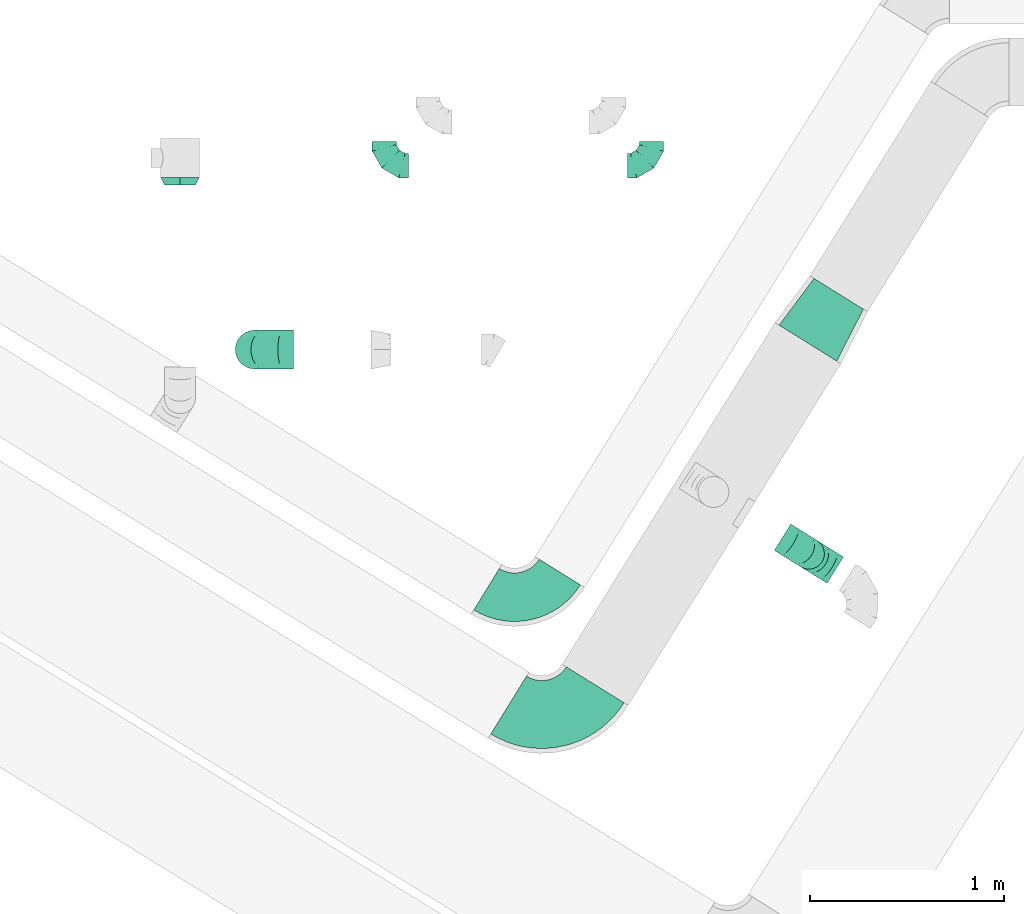
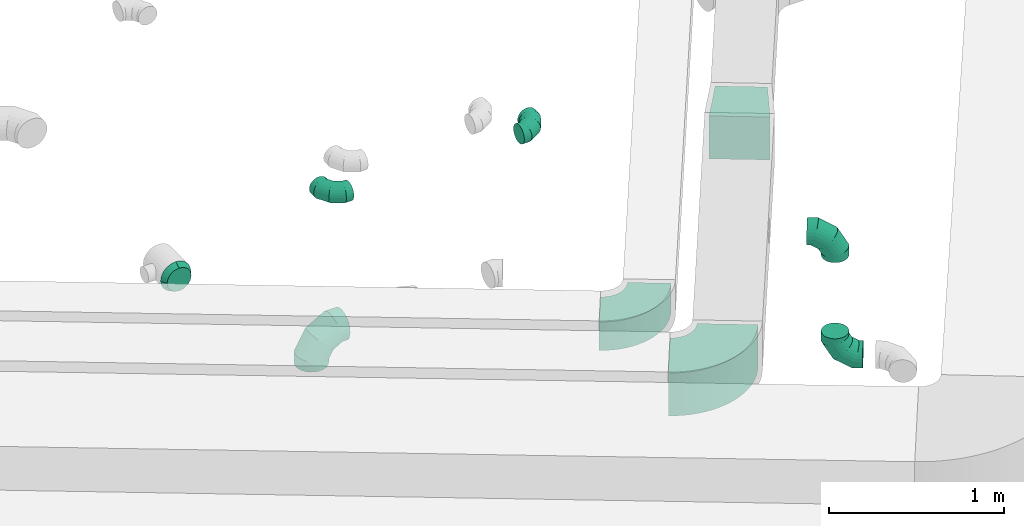
# One storey, part 37 of 97: 9 flow fittings.
"""IFC2X3 building model written with IfcOpenShell, lengths in millimetres."""

from ifc_helpers import new_model, entity, si_unit, converted_unit, derived_unit, direction, frame, frame_2d, origin, place, context, subcontext, project, spatial, polyline, circle_curve, parameter, trimmed, segment, composite_curve, outline, extrude, faceted_brep, source, transform, mapped, material, type_object, type_shapes, element, save


model = new_model("IFC2X3")

# Units and contexts
model_context = context("Model", 3, precision=0.01, world=origin(), true_north=direction((6.12303176911189e-17, 1.0)))
body_context = subcontext(model_context, "Body", "Model", "MODEL_VIEW")
ifc_project = project(units=[si_unit("LENGTHUNIT", "METRE", prefix="MILLI"), si_unit("AREAUNIT", "SQUARE_METRE"), si_unit("VOLUMEUNIT", "CUBIC_METRE"), converted_unit("PLANEANGLEUNIT", "DEGREE", entity("IfcRatioMeasure", 0.0174532925199433), si_unit("PLANEANGLEUNIT", "RADIAN"), dimensions=[0, 0, 0, 0, 0, 0, 0]), si_unit("MASSUNIT", "GRAM", prefix="KILO"), derived_unit("MASSDENSITYUNIT", [(si_unit("MASSUNIT", "GRAM", prefix="KILO"), 1), (si_unit("LENGTHUNIT", "METRE"), -3)]), derived_unit("MOMENTOFINERTIAUNIT", [(si_unit("LENGTHUNIT", "METRE"), 4)]), si_unit("TIMEUNIT", "SECOND"), si_unit("FREQUENCYUNIT", "HERTZ"), si_unit("THERMODYNAMICTEMPERATUREUNIT", "DEGREE_CELSIUS"), derived_unit("THERMALTRANSMITTANCEUNIT", [(si_unit("MASSUNIT", "GRAM", prefix="KILO"), 1), (si_unit("THERMODYNAMICTEMPERATUREUNIT", "KELVIN"), -1), (si_unit("TIMEUNIT", "SECOND"), -3)]), derived_unit("VOLUMETRICFLOWRATEUNIT", [(si_unit("LENGTHUNIT", "METRE"), 3), (si_unit("TIMEUNIT", "SECOND"), -1)]), derived_unit("MASSFLOWRATEUNIT", [(si_unit("MASSUNIT", "GRAM", prefix="KILO"), 1), (si_unit("TIMEUNIT", "SECOND"), -1)]), derived_unit("ROTATIONALFREQUENCYUNIT", [(si_unit("TIMEUNIT", "SECOND"), -1)]), si_unit("ELECTRICCURRENTUNIT", "AMPERE"), si_unit("ELECTRICVOLTAGEUNIT", "VOLT"), si_unit("POWERUNIT", "WATT"), si_unit("FORCEUNIT", "NEWTON", prefix="KILO"), si_unit("ILLUMINANCEUNIT", "LUX"), si_unit("LUMINOUSFLUXUNIT", "LUMEN"), si_unit("LUMINOUSINTENSITYUNIT", "CANDELA"), derived_unit("USERDEFINED", [(si_unit("MASSUNIT", "GRAM", prefix="KILO"), -1), (si_unit("LENGTHUNIT", "METRE"), -2), (si_unit("TIMEUNIT", "SECOND"), 3), (si_unit("LUMINOUSFLUXUNIT", "LUMEN"), 1)]), derived_unit("LINEARVELOCITYUNIT", [(si_unit("LENGTHUNIT", "METRE"), 1), (si_unit("TIMEUNIT", "SECOND"), -1)]), si_unit("PRESSUREUNIT", "PASCAL"), derived_unit("USERDEFINED", [(si_unit("LENGTHUNIT", "METRE"), -2), (si_unit("MASSUNIT", "GRAM", prefix="KILO"), 1), (si_unit("TIMEUNIT", "SECOND"), -2)]), derived_unit("LINEARFORCEUNIT", [(si_unit("MASSUNIT", "GRAM", prefix="KILO"), 1), (si_unit("LENGTHUNIT", "METRE"), 1), (si_unit("TIMEUNIT", "SECOND"), -2), (si_unit("LENGTHUNIT", "METRE"), -1)]), derived_unit("PLANARFORCEUNIT", [(si_unit("MASSUNIT", "GRAM", prefix="KILO"), 1), (si_unit("LENGTHUNIT", "METRE"), 1), (si_unit("TIMEUNIT", "SECOND"), -2), (si_unit("LENGTHUNIT", "METRE"), -2)])], contexts=[model_context])

# Site, building, storey
site_placement = place(None, origin())
site = spatial("IfcSite", under=ifc_project, at=site_placement, CompositionType="ELEMENT")
building_placement = place(site_placement, origin())
building = spatial("IfcBuilding", under=site, at=building_placement, CompositionType="ELEMENT")
storey_placement = place(building_placement, frame((0.0, 0.0, -4900.0)))
storey = spatial("IfcBuildingStorey", under=building, at=storey_placement, CompositionType="ELEMENT", Elevation=-4900.0)

# Flow fittings
ifc_material = material()
duct_fitting_type_1 = type_object("IfcDuctFittingType", PredefinedType="NOTDEFINED", material=ifc_material)
shared_shape_1 = source(origin(), body_context, "Body", "SweptSolid", [
    extrude(outline(polyline([(-164.01, -161.94), (137.03, -161.94), (161.94, 137.03), (-134.95, 186.85), (-164.01, -161.94)])), frame((150.0, 0.0, -150.0), z_axis=(0.0, 0.0, 1.0), x_axis=(0.99654575824488, 0.0830454798537382, 0.0)), (0.0, 0.0, 1.0), 300.0),
])
type_shapes(duct_fitting_type_1, [shared_shape_1])
flow_fitting_1_placement = place(storey_placement, frame((12389.17, 11235.74, 4300.0), z_axis=(0.0, 0.0, 1.0), x_axis=(0.52854381603038, 0.848906022205075, 0.0)))
element("IfcFlowFitting", 1, at=flow_fitting_1_placement, inside=storey, type_object=duct_fitting_type_1, material=ifc_material, context=body_context, shape_type="MappedRepresentation", body=[
    mapped(shared_shape_1, transform((0.0, 0.0, 0.0), scale=1.0)),
])
duct_fitting_type_2 = type_object("IfcDuctFittingType", PredefinedType="NOTDEFINED", material=ifc_material)
shared_shape_2 = source(origin(), body_context, "Body", "Brep", [
    faceted_brep([(-160.0, 0.0, -80.0), (-160.0, -20.71, -77.27), (-160.0, -40.0, -69.28), (-160.0, -56.57, -56.57), (-160.0, -69.28, -40.0), (-160.0, -77.27, -20.71), (-160.0, -80.0, 0.0), (-160.0, -77.27, 20.71), (-160.0, -69.28, 40.0), (-160.0, -56.57, 56.57), (-160.0, -40.0, 69.28), (-160.0, -20.71, 77.27), (-160.0, 0.0, 80.0), (-160.0, 20.71, 77.27), (-160.0, 40.0, 69.28), (-160.0, 56.57, 56.57), (-160.0, 69.28, 40.0), (-160.0, 77.27, 20.71), (-160.0, 80.0, 0.0), (-160.0, 77.27, -20.71), (-160.0, 69.28, -40.0), (-160.0, 56.57, -56.57), (-160.0, 40.0, -69.28), (-160.0, 20.71, -77.27), (-122.68, 20.71, 77.27), (-127.85, 40.0, 69.28), (-117.13, 0.0, 80.0), (-132.29, 56.57, 56.57), (-137.83, 77.27, 20.71), (-138.56, 80.0, 0.0), (-135.69, 69.28, 40.0), (-135.69, 69.28, -40.0), (-132.29, 56.57, -56.57), (-137.83, 77.27, -20.71), (-122.68, 20.71, -77.27), (-117.13, 0.0, -80.0), (-127.85, 40.0, -69.28), (-111.58, -20.71, -77.27), (-106.41, -40.0, -69.28), (-101.97, -56.57, -56.57), (-98.56, -69.28, -40.0), (-96.42, -77.27, -20.71), (-95.69, -80.0, 0.0), (-96.42, -77.27, 20.71), (-98.56, -69.28, 40.0), (-101.97, -56.57, 56.57), (-106.41, -40.0, 69.28), (-111.58, -20.71, 77.27), (-58.03, 58.03, 77.27), (-72.15, 72.15, 69.28), (-42.87, 42.87, 80.0), (-84.28, 84.28, 56.57), (-93.59, 93.59, 40.0), (-99.44, 99.44, 20.71), (-101.44, 101.44, 0.0), (-99.44, 99.44, -20.71), (-93.59, 93.59, -40.0), (-84.28, 84.28, -56.57), (-58.03, 58.03, -77.27), (-42.87, 42.87, -80.0), (-72.15, 72.15, -69.28), (-27.71, 27.71, -77.27), (-13.59, 13.59, -69.28), (-1.46, 1.46, -56.57), (7.85, -7.85, -40.0), (13.7, -13.7, -20.71), (15.69, -15.69, 0.0), (13.7, -13.7, 20.71), (7.85, -7.85, 40.0), (-1.46, 1.46, 56.57), (-13.59, 13.59, 69.28), (-27.71, 27.71, 77.27), (-20.71, 122.68, 77.27), (-40.0, 127.85, 69.28), (0.0, 117.13, 80.0), (-56.57, 132.29, 56.57), (-69.28, 135.69, 40.0), (-77.27, 137.83, 20.71), (-80.0, 138.56, 0.0), (-77.27, 137.83, -20.71), (-69.28, 135.69, -40.0), (-56.57, 132.29, -56.57), (-20.71, 122.68, -77.27), (0.0, 117.13, -80.0), (-40.0, 127.85, -69.28), (20.71, 111.58, -77.27), (40.0, 106.41, -69.28), (56.57, 101.97, -56.57), (69.28, 98.56, -40.0), (77.27, 96.42, -20.71), (80.0, 95.69, 0.0), (77.27, 96.42, 20.71), (69.28, 98.56, 40.0), (56.57, 101.97, 56.57), (40.0, 106.41, 69.28), (20.71, 111.58, 77.27), (-20.71, 160.0, -77.27), (-40.0, 160.0, -69.28), (-56.57, 160.0, -56.57), (-69.28, 160.0, -40.0), (-77.27, 160.0, -20.71), (-80.0, 160.0, 0.0), (-77.27, 160.0, 20.71), (-69.28, 160.0, 40.0), (-56.57, 160.0, 56.57), (-40.0, 160.0, 69.28), (-20.71, 160.0, 77.27), (0.0, 160.0, 80.0), (20.71, 160.0, 77.27), (40.0, 160.0, 69.28), (56.57, 160.0, 56.57), (69.28, 160.0, 40.0), (77.27, 160.0, 20.71), (80.0, 160.0, 0.0), (77.27, 160.0, -20.71), (69.28, 160.0, -40.0), (56.57, 160.0, -56.57), (40.0, 160.0, -69.28), (20.71, 160.0, -77.27), (0.0, 160.0, -80.0)], [[[0, 1, 2, 3, 4, 5, 6, 7, 8, 9, 10, 11, 12, 13, 14, 15, 16, 17, 18, 19, 20, 21, 22, 23]], [[24, 25, 14, 13]], [[26, 24, 13, 12]], [[14, 25, 27, 15]], [[28, 29, 18, 17]], [[30, 28, 17, 16]], [[15, 27, 30, 16]], [[20, 31, 32, 21]], [[33, 31, 20, 19]], [[18, 29, 33, 19]], [[34, 35, 0, 23]], [[36, 34, 23, 22]], [[32, 36, 22, 21]], [[1, 0, 35, 37]], [[2, 1, 37, 38]], [[3, 2, 38, 39]], [[5, 4, 40, 41]], [[6, 5, 41, 42]], [[39, 40, 4, 3]], [[6, 42, 43, 7]], [[7, 43, 44, 8]], [[8, 44, 45, 9]], [[9, 45, 46, 10]], [[10, 46, 47, 11]], [[26, 12, 11, 47]], [[48, 49, 25, 24]], [[50, 48, 24, 26]], [[27, 25, 49, 51]], [[52, 53, 28, 30]], [[51, 52, 30, 27]], [[29, 28, 53, 54]], [[55, 56, 31, 33]], [[54, 55, 33, 29]], [[32, 31, 56, 57]], [[58, 59, 35, 34]], [[60, 58, 34, 36]], [[57, 60, 36, 32]], [[37, 35, 59, 61]], [[38, 37, 61, 62]], [[39, 38, 62, 63]], [[41, 40, 64, 65]], [[42, 41, 65, 66]], [[63, 64, 40, 39]], [[43, 42, 66, 67]], [[44, 43, 67, 68]], [[68, 69, 45, 44]], [[46, 45, 69, 70]], [[47, 46, 70, 71]], [[26, 47, 71, 50]], [[72, 73, 49, 48]], [[74, 72, 48, 50]], [[51, 49, 73, 75]], [[76, 77, 53, 52]], [[75, 76, 52, 51]], [[54, 53, 77, 78]], [[79, 80, 56, 55]], [[78, 79, 55, 54]], [[57, 56, 80, 81]], [[82, 83, 59, 58]], [[84, 82, 58, 60]], [[81, 84, 60, 57]], [[61, 59, 83, 85]], [[62, 61, 85, 86]], [[63, 62, 86, 87]], [[65, 64, 88, 89]], [[66, 65, 89, 90]], [[87, 88, 64, 63]], [[67, 66, 90, 91]], [[68, 67, 91, 92]], [[92, 93, 69, 68]], [[70, 69, 93, 94]], [[71, 70, 94, 95]], [[50, 71, 95, 74]], [[96, 97, 98, 99, 100, 101, 102, 103, 104, 105, 106, 107, 108, 109, 110, 111, 112, 113, 114, 115, 116, 117, 118, 119]], [[72, 74, 107, 106]], [[73, 72, 106, 105]], [[75, 73, 105, 104]], [[77, 76, 103, 102]], [[78, 77, 102, 101]], [[75, 104, 103, 76]], [[78, 101, 100, 79]], [[79, 100, 99, 80]], [[80, 99, 98, 81]], [[84, 97, 96, 82]], [[82, 96, 119, 83]], [[84, 81, 98, 97]], [[118, 117, 86, 85]], [[119, 118, 85, 83]], [[116, 87, 86, 117]], [[88, 115, 114, 89]], [[89, 114, 113, 90]], [[115, 88, 87, 116]], [[112, 111, 92, 91]], [[113, 112, 91, 90]], [[111, 110, 93, 92]], [[95, 94, 109, 108]], [[74, 95, 108, 107]], [[110, 109, 94, 93]]]),
])
type_shapes(duct_fitting_type_2, [shared_shape_2])
for number, where, z_axis, x_axis in (
    (2, (12394.14, 10151.17, 4300.0), (0.528686541592224, 0.848817142109685, 0.0), (0.848817142109685, -0.528686541592224, 0.0)),
    (3, (12394.14, 10151.17, 3447.19), (0.528686541592227, 0.848817142109683, 0.0), (-0.848817142109683, 0.528686541592227, 0.0)),
):
    element("IfcFlowFitting", number, at=place(storey_placement, frame(where, z_axis=z_axis, x_axis=x_axis)), inside=storey, type_object=duct_fitting_type_2, material=ifc_material, context=body_context, shape_type="MappedRepresentation", body=[
        mapped(shared_shape_2, transform((0.0, 0.0, 0.0), scale=1.0)),
    ])
duct_fitting_type_3 = type_object("IfcDuctFittingType", PredefinedType="NOTDEFINED", material=ifc_material)
shared_shape_3 = source(origin(), body_context, "Body", "Brep", [
    faceted_brep([(40.0, -58.78, -80.9), (40.0, -30.9, -95.11), (40.0, 0.0, -100.0), (40.0, 30.9, -95.11), (40.0, 58.78, -80.9), (40.0, 80.9, -58.78), (40.0, 95.11, -30.9), (40.0, 100.0, 0.0), (40.0, 95.11, 30.9), (40.0, 80.9, 58.78), (40.0, 58.78, 80.9), (40.0, 30.9, 95.11), (40.0, 0.0, 100.0), (40.0, -30.9, 95.11), (40.0, -58.78, 80.9), (40.0, -80.9, 58.78), (40.0, -95.11, 30.9), (40.0, -100.0, 0.0), (40.0, -95.11, -30.9), (40.0, -80.9, -58.78), (0.0, -30.61, -73.91), (0.0, -43.59, -65.24), (0.0, -56.57, -56.57), (0.0, -65.24, -43.59), (0.0, -73.91, -30.61), (0.0, -76.96, -15.31), (0.0, -80.0, 0.0), (0.0, -76.96, 15.31), (0.0, -73.91, 30.61), (0.0, -65.24, 43.59), (0.0, -56.57, 56.57), (0.0, -43.59, 65.24), (0.0, -30.61, 73.91), (0.0, -15.31, 76.96), (0.0, 0.0, 80.0), (0.0, 15.31, 76.96), (0.0, 30.61, 73.91), (0.0, 43.59, 65.24), (0.0, 56.57, 56.57), (0.0, 65.24, 43.59), (0.0, 73.91, 30.61), (0.0, 76.96, 15.31), (0.0, 80.0, 0.0), (0.0, 76.96, -15.31), (0.0, 73.91, -30.61), (0.0, 65.24, -43.59), (0.0, 56.57, -56.57), (0.0, 43.59, -65.24), (0.0, 30.61, -73.91), (0.0, 15.31, -76.96), (0.0, 0.0, -80.0), (0.0, -15.31, -76.96)], [[[0, 1, 2, 3, 4, 5, 6, 7, 8, 9, 10, 11, 12, 13, 14, 15, 16, 17, 18, 19]], [[20, 21, 22, 23, 24, 25, 26, 27, 28, 29, 30, 31, 32, 33, 34, 35, 36, 37, 38, 39, 40, 41, 42, 43, 44, 45, 46, 47, 48, 49, 50, 51]], [[7, 41, 8]], [[40, 9, 8]], [[10, 38, 37, 36]], [[39, 38, 9, 40]], [[11, 36, 35]], [[34, 12, 35]], [[41, 40, 8]], [[10, 36, 11]], [[35, 12, 11]], [[41, 7, 42]], [[38, 10, 9]], [[12, 33, 13]], [[32, 14, 13]], [[15, 30, 29, 28]], [[31, 30, 14, 32]], [[16, 28, 27]], [[26, 17, 27]], [[33, 32, 13]], [[15, 28, 16]], [[27, 17, 16]], [[33, 12, 34]], [[30, 15, 14]], [[17, 25, 18]], [[24, 19, 18]], [[0, 22, 21, 20]], [[23, 22, 19, 24]], [[1, 20, 51]], [[50, 2, 51]], [[25, 24, 18]], [[0, 20, 1]], [[51, 2, 1]], [[25, 17, 26]], [[22, 0, 19]], [[2, 49, 3]], [[48, 4, 3]], [[5, 46, 45, 44]], [[47, 46, 4, 48]], [[6, 44, 43]], [[42, 7, 43]], [[49, 48, 3]], [[5, 44, 6]], [[43, 7, 6]], [[49, 2, 50]], [[46, 5, 4]]]),
])
type_shapes(duct_fitting_type_3, [shared_shape_3])
flow_fitting_2_placement = place(storey_placement, frame((9153.25, 12050.19, 3950.0), z_axis=(0.0, 0.0, 1.0), x_axis=(0.0, 1.0, 0.0)))
element("IfcFlowFitting", 4, at=flow_fitting_2_placement, inside=storey, type_object=duct_fitting_type_3, material=ifc_material, context=body_context, shape_type="MappedRepresentation", body=[
    mapped(shared_shape_3, transform((0.0, 0.0, 0.0), scale=1.0)),
])
duct_fitting_type_4 = type_object("IfcDuctFittingType", PredefinedType="NOTDEFINED", material=ifc_material)
shared_shape_4 = source(origin(), body_context, "Body", "Brep", [
    faceted_brep([(-200.0, 0.0, -100.0), (-200.0, -25.88, -96.59), (-200.0, -50.0, -86.6), (-200.0, -70.71, -70.71), (-200.0, -86.6, -50.0), (-200.0, -96.59, -25.88), (-200.0, -100.0, 0.0), (-200.0, -96.59, 25.88), (-200.0, -86.6, 50.0), (-200.0, -70.71, 70.71), (-200.0, -50.0, 86.6), (-200.0, -25.88, 96.59), (-200.0, 0.0, 100.0), (-200.0, 25.88, 96.59), (-200.0, 50.0, 86.6), (-200.0, 70.71, 70.71), (-200.0, 86.6, 50.0), (-200.0, 96.59, 25.88), (-200.0, 100.0, 0.0), (-200.0, 96.59, -25.88), (-200.0, 86.6, -50.0), (-200.0, 70.71, -70.71), (-200.0, 50.0, -86.6), (-200.0, 25.88, -96.59), (-153.35, 25.88, 96.59), (-159.81, 50.0, 86.6), (-146.41, 0.0, 100.0), (-165.36, 70.71, 70.71), (-172.29, 96.59, 25.88), (-173.21, 100.0, 0.0), (-169.62, 86.6, 50.0), (-169.62, 86.6, -50.0), (-165.36, 70.71, -70.71), (-172.29, 96.59, -25.88), (-153.35, 25.88, -96.59), (-146.41, 0.0, -100.0), (-159.81, 50.0, -86.6), (-139.48, -25.88, -96.59), (-133.01, -50.0, -86.6), (-127.46, -70.71, -70.71), (-123.21, -86.6, -50.0), (-120.53, -96.59, -25.88), (-119.62, -100.0, 0.0), (-120.53, -96.59, 25.88), (-123.21, -86.6, 50.0), (-127.46, -70.71, 70.71), (-133.01, -50.0, 86.6), (-139.48, -25.88, 96.59), (-72.54, 72.54, 96.59), (-90.19, 90.19, 86.6), (-53.59, 53.59, 100.0), (-105.35, 105.35, 70.71), (-116.99, 116.99, 50.0), (-124.3, 124.3, 25.88), (-126.79, 126.79, 0.0), (-124.3, 124.3, -25.88), (-116.99, 116.99, -50.0), (-105.35, 105.35, -70.71), (-72.54, 72.54, -96.59), (-53.59, 53.59, -100.0), (-90.19, 90.19, -86.6), (-34.64, 34.64, -96.59), (-16.99, 16.99, -86.6), (-1.83, 1.83, -70.71), (9.81, -9.81, -50.0), (17.12, -17.12, -25.88), (19.62, -19.62, 0.0), (17.12, -17.12, 25.88), (9.81, -9.81, 50.0), (-1.83, 1.83, 70.71), (-16.99, 16.99, 86.6), (-34.64, 34.64, 96.59), (-25.88, 153.35, 96.59), (-50.0, 159.81, 86.6), (0.0, 146.41, 100.0), (-70.71, 165.36, 70.71), (-86.6, 169.62, 50.0), (-96.59, 172.29, 25.88), (-100.0, 173.21, 0.0), (-96.59, 172.29, -25.88), (-86.6, 169.62, -50.0), (-70.71, 165.36, -70.71), (-25.88, 153.35, -96.59), (0.0, 146.41, -100.0), (-50.0, 159.81, -86.6), (25.88, 139.48, -96.59), (50.0, 133.01, -86.6), (70.71, 127.46, -70.71), (86.6, 123.21, -50.0), (96.59, 120.53, -25.88), (100.0, 119.62, 0.0), (96.59, 120.53, 25.88), (86.6, 123.21, 50.0), (70.71, 127.46, 70.71), (50.0, 133.01, 86.6), (25.88, 139.48, 96.59), (-25.88, 200.0, -96.59), (-50.0, 200.0, -86.6), (-70.71, 200.0, -70.71), (-86.6, 200.0, -50.0), (-96.59, 200.0, -25.88), (-100.0, 200.0, 0.0), (-96.59, 200.0, 25.88), (-86.6, 200.0, 50.0), (-70.71, 200.0, 70.71), (-50.0, 200.0, 86.6), (-25.88, 200.0, 96.59), (0.0, 200.0, 100.0), (25.88, 200.0, 96.59), (50.0, 200.0, 86.6), (70.71, 200.0, 70.71), (86.6, 200.0, 50.0), (96.59, 200.0, 25.88), (100.0, 200.0, 0.0), (96.59, 200.0, -25.88), (86.6, 200.0, -50.0), (70.71, 200.0, -70.71), (50.0, 200.0, -86.6), (25.88, 200.0, -96.59), (0.0, 200.0, -100.0)], [[[0, 1, 2, 3, 4, 5, 6, 7, 8, 9, 10, 11, 12, 13, 14, 15, 16, 17, 18, 19, 20, 21, 22, 23]], [[24, 25, 14, 13]], [[26, 24, 13, 12]], [[14, 25, 27, 15]], [[28, 29, 18, 17]], [[30, 28, 17, 16]], [[15, 27, 30, 16]], [[20, 31, 32, 21]], [[33, 31, 20, 19]], [[18, 29, 33, 19]], [[34, 35, 0, 23]], [[36, 34, 23, 22]], [[32, 36, 22, 21]], [[1, 0, 35, 37]], [[2, 1, 37, 38]], [[38, 39, 3, 2]], [[5, 4, 40, 41]], [[6, 5, 41, 42]], [[39, 40, 4, 3]], [[6, 42, 43, 7]], [[7, 43, 44, 8]], [[8, 44, 45, 9]], [[9, 45, 46, 10]], [[10, 46, 47, 11]], [[26, 12, 11, 47]], [[48, 49, 25, 24]], [[50, 48, 24, 26]], [[27, 25, 49, 51]], [[52, 53, 28, 30]], [[51, 52, 30, 27]], [[29, 28, 53, 54]], [[55, 56, 31, 33]], [[54, 55, 33, 29]], [[32, 31, 56, 57]], [[58, 59, 35, 34]], [[60, 58, 34, 36]], [[57, 60, 36, 32]], [[37, 35, 59, 61]], [[38, 37, 61, 62]], [[39, 38, 62, 63]], [[41, 40, 64, 65]], [[42, 41, 65, 66]], [[63, 64, 40, 39]], [[43, 42, 66, 67]], [[44, 43, 67, 68]], [[68, 69, 45, 44]], [[46, 45, 69, 70]], [[47, 46, 70, 71]], [[26, 47, 71, 50]], [[72, 73, 49, 48]], [[74, 72, 48, 50]], [[51, 49, 73, 75]], [[76, 77, 53, 52]], [[75, 76, 52, 51]], [[54, 53, 77, 78]], [[79, 80, 56, 55]], [[78, 79, 55, 54]], [[57, 56, 80, 81]], [[82, 83, 59, 58]], [[84, 82, 58, 60]], [[81, 84, 60, 57]], [[61, 59, 83, 85]], [[62, 61, 85, 86]], [[63, 62, 86, 87]], [[65, 64, 88, 89]], [[66, 65, 89, 90]], [[87, 88, 64, 63]], [[67, 66, 90, 91]], [[68, 67, 91, 92]], [[92, 93, 69, 68]], [[70, 69, 93, 94]], [[71, 70, 94, 95]], [[50, 71, 95, 74]], [[96, 97, 98, 99, 100, 101, 102, 103, 104, 105, 106, 107, 108, 109, 110, 111, 112, 113, 114, 115, 116, 117, 118, 119]], [[72, 74, 107, 106]], [[73, 72, 106, 105]], [[75, 73, 105, 104]], [[102, 101, 78, 77]], [[103, 102, 77, 76]], [[75, 104, 103, 76]], [[78, 101, 100, 79]], [[79, 100, 99, 80]], [[80, 99, 98, 81]], [[84, 97, 96, 82]], [[82, 96, 119, 83]], [[84, 81, 98, 97]], [[118, 117, 86, 85]], [[119, 118, 85, 83]], [[116, 87, 86, 117]], [[88, 115, 114, 89]], [[89, 114, 113, 90]], [[115, 88, 87, 116]], [[91, 90, 113, 112]], [[92, 91, 112, 111]], [[111, 110, 93, 92]], [[95, 94, 109, 108]], [[74, 95, 108, 107]], [[110, 109, 94, 93]]]),
])
type_shapes(duct_fitting_type_4, [shared_shape_4])
flow_fitting_3_placement = place(storey_placement, frame((9538.1, 11202.85, 3950.0), z_axis=(0.0, -1.0, 0.0), x_axis=(-1.0, 0.0, 0.0)))
element("IfcFlowFitting", 5, at=flow_fitting_3_placement, inside=storey, type_object=duct_fitting_type_4, material=ifc_material, context=body_context, shape_type="MappedRepresentation", body=[
    mapped(shared_shape_4, transform((0.0, 0.0, 0.0), scale=1.0)),
])
duct_fitting_type_5 = type_object("IfcDuctFittingType", PredefinedType="NOTDEFINED", material=ifc_material)
shared_shape_5 = source(origin(), body_context, "Body", "Brep", [
    faceted_brep([(-125.0, 0.0, -62.5), (-125.0, -16.18, -60.37), (-125.0, -31.25, -54.13), (-125.0, -44.19, -44.19), (-125.0, -54.13, -31.25), (-125.0, -60.37, -16.18), (-125.0, -62.5, 0.0), (-125.0, -60.37, 16.18), (-125.0, -54.13, 31.25), (-125.0, -44.19, 44.19), (-125.0, -31.25, 54.13), (-125.0, -16.18, 60.37), (-125.0, 0.0, 62.5), (-125.0, 16.18, 60.37), (-125.0, 31.25, 54.13), (-125.0, 44.19, 44.19), (-125.0, 54.13, 31.25), (-125.0, 60.37, 16.18), (-125.0, 62.5, 0.0), (-125.0, 60.37, -16.18), (-125.0, 54.13, -31.25), (-125.0, 44.19, -44.19), (-125.0, 31.25, -54.13), (-125.0, 16.18, -60.37), (-95.84, 16.18, 60.37), (-99.88, 31.25, 54.13), (-91.51, 0.0, 62.5), (-103.35, 44.19, 44.19), (-107.68, 60.37, 16.18), (-108.25, 62.5, 0.0), (-106.01, 54.13, 31.25), (-106.01, 54.13, -31.25), (-103.35, 44.19, -44.19), (-107.68, 60.37, -16.18), (-95.84, 16.18, -60.37), (-91.51, 0.0, -62.5), (-99.88, 31.25, -54.13), (-87.17, -16.18, -60.37), (-83.13, -31.25, -54.13), (-79.66, -44.19, -44.19), (-77.0, -54.13, -31.25), (-75.33, -60.37, -16.18), (-74.76, -62.5, 0.0), (-75.33, -60.37, 16.18), (-77.0, -54.13, 31.25), (-79.66, -44.19, 44.19), (-83.13, -31.25, 54.13), (-87.17, -16.18, 60.37), (-45.34, 45.34, 60.37), (-56.37, 56.37, 54.13), (-33.49, 33.49, 62.5), (-65.85, 65.85, 44.19), (-73.12, 73.12, 31.25), (-77.69, 77.69, 16.18), (-79.25, 79.25, 0.0), (-77.69, 77.69, -16.18), (-73.12, 73.12, -31.25), (-65.85, 65.85, -44.19), (-45.34, 45.34, -60.37), (-33.49, 33.49, -62.5), (-56.37, 56.37, -54.13), (-21.65, 21.65, -60.37), (-10.62, 10.62, -54.13), (-1.14, 1.14, -44.19), (6.13, -6.13, -31.25), (10.7, -10.7, -16.18), (12.26, -12.26, 0.0), (10.7, -10.7, 16.18), (6.13, -6.13, 31.25), (-1.14, 1.14, 44.19), (-10.62, 10.62, 54.13), (-21.65, 21.65, 60.37), (-16.18, 95.84, 60.37), (-31.25, 99.88, 54.13), (0.0, 91.51, 62.5), (-44.19, 103.35, 44.19), (-54.13, 106.01, 31.25), (-60.37, 107.68, 16.18), (-62.5, 108.25, 0.0), (-60.37, 107.68, -16.18), (-54.13, 106.01, -31.25), (-44.19, 103.35, -44.19), (-16.18, 95.84, -60.37), (0.0, 91.51, -62.5), (-31.25, 99.88, -54.13), (16.18, 87.17, -60.37), (31.25, 83.13, -54.13), (44.19, 79.66, -44.19), (54.13, 77.0, -31.25), (60.37, 75.33, -16.18), (62.5, 74.76, 0.0), (60.37, 75.33, 16.18), (54.13, 77.0, 31.25), (44.19, 79.66, 44.19), (31.25, 83.13, 54.13), (16.18, 87.17, 60.37), (-16.18, 125.0, -60.37), (-31.25, 125.0, -54.13), (-44.19, 125.0, -44.19), (-54.13, 125.0, -31.25), (-60.37, 125.0, -16.18), (-62.5, 125.0, 0.0), (-60.37, 125.0, 16.18), (-54.13, 125.0, 31.25), (-44.19, 125.0, 44.19), (-31.25, 125.0, 54.13), (-16.18, 125.0, 60.37), (0.0, 125.0, 62.5), (16.18, 125.0, 60.37), (31.25, 125.0, 54.13), (44.19, 125.0, 44.19), (54.13, 125.0, 31.25), (60.37, 125.0, 16.18), (62.5, 125.0, 0.0), (60.37, 125.0, -16.18), (54.13, 125.0, -31.25), (44.19, 125.0, -44.19), (31.25, 125.0, -54.13), (16.18, 125.0, -60.37), (0.0, 125.0, -62.5)], [[[0, 1, 2, 3, 4, 5, 6, 7, 8, 9, 10, 11, 12, 13, 14, 15, 16, 17, 18, 19, 20, 21, 22, 23]], [[24, 25, 14, 13]], [[26, 24, 13, 12]], [[14, 25, 27, 15]], [[28, 29, 18, 17]], [[30, 28, 17, 16]], [[15, 27, 30, 16]], [[20, 31, 32, 21]], [[33, 31, 20, 19]], [[18, 29, 33, 19]], [[34, 35, 0, 23]], [[36, 34, 23, 22]], [[21, 32, 36, 22]], [[1, 0, 35, 37]], [[2, 1, 37, 38]], [[38, 39, 3, 2]], [[5, 4, 40, 41]], [[6, 5, 41, 42]], [[39, 40, 4, 3]], [[6, 42, 43, 7]], [[7, 43, 44, 8]], [[45, 9, 8, 44]], [[9, 45, 46, 10]], [[10, 46, 47, 11]], [[26, 12, 11, 47]], [[48, 49, 25, 24]], [[50, 48, 24, 26]], [[27, 25, 49, 51]], [[52, 53, 28, 30]], [[51, 52, 30, 27]], [[29, 28, 53, 54]], [[55, 56, 31, 33]], [[54, 55, 33, 29]], [[57, 32, 31, 56]], [[58, 59, 35, 34]], [[60, 58, 34, 36]], [[57, 60, 36, 32]], [[37, 35, 59, 61]], [[38, 37, 61, 62]], [[39, 38, 62, 63]], [[41, 40, 64, 65]], [[42, 41, 65, 66]], [[63, 64, 40, 39]], [[43, 42, 66, 67]], [[44, 43, 67, 68]], [[68, 69, 45, 44]], [[46, 45, 69, 70]], [[47, 46, 70, 71]], [[26, 47, 71, 50]], [[72, 73, 49, 48]], [[74, 72, 48, 50]], [[51, 49, 73, 75]], [[76, 77, 53, 52]], [[75, 76, 52, 51]], [[54, 53, 77, 78]], [[79, 80, 56, 55]], [[78, 79, 55, 54]], [[81, 57, 56, 80]], [[82, 83, 59, 58]], [[84, 82, 58, 60]], [[81, 84, 60, 57]], [[61, 59, 83, 85]], [[62, 61, 85, 86]], [[63, 62, 86, 87]], [[65, 64, 88, 89]], [[66, 65, 89, 90]], [[87, 88, 64, 63]], [[67, 66, 90, 91]], [[68, 67, 91, 92]], [[92, 93, 69, 68]], [[70, 69, 93, 94]], [[71, 70, 94, 95]], [[50, 71, 95, 74]], [[96, 97, 98, 99, 100, 101, 102, 103, 104, 105, 106, 107, 108, 109, 110, 111, 112, 113, 114, 115, 116, 117, 118, 119]], [[72, 74, 107, 106]], [[73, 72, 106, 105]], [[75, 73, 105, 104]], [[77, 76, 103, 102]], [[78, 77, 102, 101]], [[75, 104, 103, 76]], [[78, 101, 100, 79]], [[79, 100, 99, 80]], [[80, 99, 98, 81]], [[96, 119, 83, 82]], [[97, 96, 82, 84]], [[84, 81, 98, 97]], [[83, 119, 118, 85]], [[85, 118, 117, 86]], [[116, 87, 86, 117]], [[88, 115, 114, 89]], [[89, 114, 113, 90]], [[115, 88, 87, 116]], [[91, 90, 113, 112]], [[92, 91, 112, 111]], [[111, 110, 93, 92]], [[95, 94, 109, 108]], [[74, 95, 108, 107]], [[110, 109, 94, 93]]]),
])
type_shapes(duct_fitting_type_5, [shared_shape_5])
flow_fitting_4_placement = place(storey_placement, frame((10206.12, 12150.59, 4100.0), z_axis=(0.0, 0.0, 1.0), x_axis=(0.0, -1.0, 0.0)))
element("IfcFlowFitting", 6, at=flow_fitting_4_placement, inside=storey, type_object=duct_fitting_type_5, material=ifc_material, context=body_context, shape_type="MappedRepresentation", body=[
    mapped(shared_shape_5, transform((0.0, 0.0, 0.0), scale=1.0)),
])
flow_fitting_5_placement = place(storey_placement, frame((11583.09, 12150.59, 4100.0)))
element("IfcFlowFitting", 7, at=flow_fitting_5_placement, inside=storey, type_object=duct_fitting_type_5, material=ifc_material, context=body_context, shape_type="MappedRepresentation", body=[
    mapped(shared_shape_5, transform((0.0, 0.0, 0.0), scale=1.0)),
])
duct_fitting_type_6 = type_object("IfcDuctFittingType", PredefinedType="NOTDEFINED", material=ifc_material)
shared_shape_6 = source(origin(), body_context, "Body", "SweptSolid", [
    extrude(outline(composite_curve([segment(polyline([(-336.83, -162.5), (13.17, -162.5)]), True, "CONTINUOUS"), segment(trimmed(circle_curve(frame_2d((163.17, -162.5), x_axis=(-0.00414359549645837, 0.999991415271325)), 150.0), [parameter(0.0)], [parameter(89.7625887866742)], True, "PARAMETER"), False, "CONTINUOUS"), segment(polyline([(162.55, -12.5), (161.1, 337.5)]), True, "CONTINUOUS"), segment(trimmed(circle_curve(frame_2d((163.17, -162.5), x_axis=(-0.00414359549645837, 0.999991415271325)), 500.0), [parameter(0.0)], [parameter(89.7625887866742)], True, "PARAMETER"), True, "CONTINUOUS")], self_intersect=False)), frame((-161.16, 161.83, -150.0), z_axis=(0.0, 0.0, 1.0), x_axis=(-0.999991415271332, 0.00414359549643521, 0.0)), (0.0, 0.0, 1.0), 300.0),
])
type_shapes(duct_fitting_type_6, [shared_shape_6])
flow_fitting_6_placement = place(storey_placement, frame((11122.13, 9200.72, 4300.0), z_axis=(0.0, 0.0, 1.0), x_axis=(0.851088806352981, -0.525021755454627, 0.0)))
element("IfcFlowFitting", 8, at=flow_fitting_6_placement, inside=storey, type_object=duct_fitting_type_6, material=ifc_material, context=body_context, shape_type="MappedRepresentation", body=[
    mapped(shared_shape_6, transform((0.0, 0.0, 0.0), scale=1.0)),
])
duct_fitting_type_7 = type_object("IfcDuctFittingType", PredefinedType="NOTDEFINED", material=ifc_material)
shared_shape_7 = source(origin(), body_context, "Body", "SweptSolid", [
    extrude(outline(composite_curve([segment(polyline([(-261.93, -137.5), (-11.93, -137.5)]), True, "CONTINUOUS"), segment(trimmed(circle_curve(frame_2d((138.07, -137.5), x_axis=(-0.00414359549634469, 0.999991415271353)), 150.0), [parameter(0.0)], [parameter(89.7625887866784)], True, "PARAMETER"), False, "CONTINUOUS"), segment(polyline([(137.45, 12.5), (136.41, 262.5)]), True, "CONTINUOUS"), segment(trimmed(circle_curve(frame_2d((138.07, -137.5), x_axis=(-0.00414359549634469, 0.999991415271353)), 400.0), [parameter(0.0)], [parameter(89.7625887866784)], True, "PARAMETER"), True, "CONTINUOUS")], self_intersect=False)), frame((-136.36, 136.93, -100.0), z_axis=(0.0, 0.0, 1.0), x_axis=(-0.999991415271333, 0.00414359549636382, 0.0)), (0.0, 0.0, 1.0), 200.0),
])
type_shapes(duct_fitting_type_7, [shared_shape_7])
flow_fitting_7_placement = place(storey_placement, frame((10965.92, 9823.73, 4350.0), z_axis=(0.0, 0.0, 1.0), x_axis=(0.851088806352979, -0.52502175545463, 0.0)))
element("IfcFlowFitting", 9, at=flow_fitting_7_placement, inside=storey, type_object=duct_fitting_type_7, material=ifc_material, context=body_context, shape_type="MappedRepresentation", body=[
    mapped(shared_shape_7, transform((0.0, 0.0, 0.0), scale=1.0)),
])

save(model, "model.ifc")
